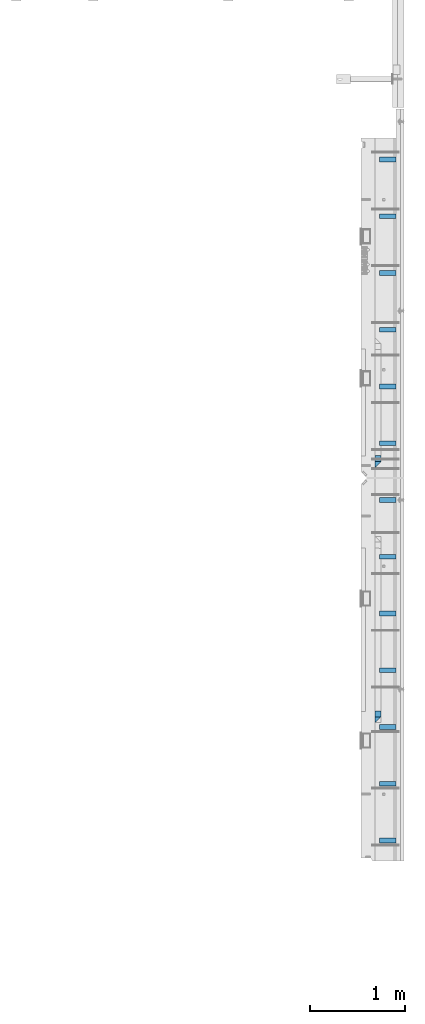
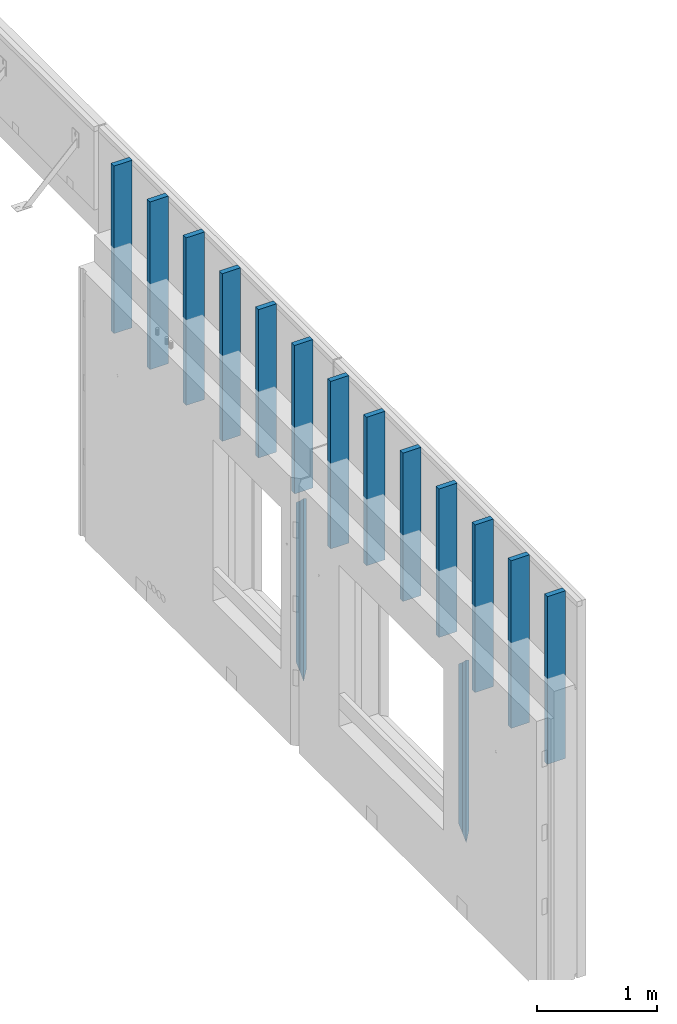
# One storey, part 5 of 153: 17 columns, 2 elements without a shape of their own.
"""IFC2X3 building model written with IfcOpenShell, lengths in millimetres."""

from ifc_helpers import new_model, si_unit, frame, origin_with_axes, place, context, subcontext, project, spatial, faceted_brep, material, type_object, element, aggregate, save


model = new_model("IFC2X3")

# Units and contexts
model_context = context("Model", 3, precision=1e-05, world=origin_with_axes())
body_context = subcontext(model_context, "Body", "Model", "MODEL_VIEW")
ifc_project = project(units=[si_unit("LENGTHUNIT", "METRE", prefix="MILLI"), si_unit("AREAUNIT", "SQUARE_METRE"), si_unit("VOLUMEUNIT", "CUBIC_METRE"), si_unit("MASSUNIT", "GRAM", prefix="KILO"), si_unit("TIMEUNIT", "SECOND"), si_unit("PLANEANGLEUNIT", "RADIAN"), si_unit("SOLIDANGLEUNIT", "STERADIAN"), si_unit("THERMODYNAMICTEMPERATUREUNIT", "DEGREE_CELSIUS"), si_unit("LUMINOUSINTENSITYUNIT", "LUMEN")], contexts=[model_context])

# Site, building, storey
site_placement = place(None, origin_with_axes())
site = spatial("IfcSite", under=ifc_project, at=site_placement, CompositionType="ELEMENT")
building_placement = place(site_placement, origin_with_axes())
building = spatial("IfcBuilding", under=site, at=building_placement, CompositionType="ELEMENT")
storey_placement = place(building_placement, origin_with_axes())
storey = spatial("IfcBuildingStorey", under=building, at=storey_placement, Name="8", CompositionType="ELEMENT", Elevation=0.0)

# Assembly, columns
assembly_1_placement = place(storey_placement, origin_with_axes())
assembly_1 = element("IfcElementAssembly", 1, at=assembly_1_placement, inside=storey, AssemblyPlace="NOTDEFINED", PredefinedType="REINFORCEMENT_UNIT")
ifc_material_1 = material(Name="TIMBER/T24")
column_type_1 = type_object("IfcColumnType", Name="PK50X175", PredefinedType="NOTDEFINED")
column_1_placement = place(assembly_1_placement, frame((35192.5, 13150.0002441406, 101870.0), z_axis=(-1.0, 3.00000001838171e-08, 0.0), x_axis=(0.0, 0.0, 1.0)))
column_1 = element("IfcColumn", 2, at=column_1_placement, type_object=column_type_1, material=ifc_material_1, ObjectType="PK50X175", context=body_context, shape_type="Brep", body=[
    faceted_brep([(0.0, 25.0, 87.5), (0.0, -25.0, 87.5), (1700.0, -25.0, 87.5), (1700.0, 25.0, 87.5), (0.0, -25.0, -87.5), (1700.0, -25.0, -87.5), (0.0, 25.0, -87.5), (1700.0, 25.0, -87.5)], [[[0, 1, 2, 3]], [[1, 4, 5, 2]], [[4, 6, 7, 5]], [[6, 0, 3, 7]], [[5, 7, 3, 2]], [[6, 4, 1, 0]]]),
])
column_2_placement = place(assembly_1_placement, frame((35192.5, 13750.0002441406, 101870.0), z_axis=(-1.0, 3.00000001838171e-08, 0.0), x_axis=(0.0, 0.0, 1.0)))
column_2 = element("IfcColumn", 3, at=column_2_placement, type_object=column_type_1, material=ifc_material_1, ObjectType="PK50X175", context=body_context, shape_type="Brep", body=[
    faceted_brep([(0.0, 25.0, 87.5), (0.0, -25.0, 87.5), (1700.0, -25.0, 87.5), (1700.0, 25.0, 87.5), (0.0, -25.0, -87.5), (1700.0, -25.0, -87.5), (0.0, 25.0, -87.5), (1700.0, 25.0, -87.5)], [[[0, 1, 2, 3]], [[1, 4, 5, 2]], [[4, 6, 7, 5]], [[6, 0, 3, 7]], [[5, 7, 3, 2]], [[6, 4, 1, 0]]]),
])
column_3_placement = place(assembly_1_placement, frame((35192.5, 14350.0002441406, 101870.0), z_axis=(-1.0, 3.00000001838171e-08, 0.0), x_axis=(0.0, 0.0, 1.0)))
column_3 = element("IfcColumn", 4, at=column_3_placement, type_object=column_type_1, material=ifc_material_1, ObjectType="PK50X175", context=body_context, shape_type="Brep", body=[
    faceted_brep([(0.0, 25.0, 87.5), (0.0, -25.0, 87.5), (1700.0, -25.0, 87.5), (1700.0, 25.0, 87.5), (0.0, -25.0, -87.5), (1700.0, -25.0, -87.5), (0.0, 25.0, -87.5), (1700.0, 25.0, -87.5)], [[[0, 1, 2, 3]], [[1, 4, 5, 2]], [[4, 6, 7, 5]], [[6, 0, 3, 7]], [[5, 7, 3, 2]], [[6, 4, 1, 0]]]),
])
column_4_placement = place(assembly_1_placement, frame((35192.5, 14950.0002441406, 102065.0), z_axis=(-1.0, 3.00000001838171e-08, 0.0), x_axis=(0.0, 0.0, 1.0)))
column_4 = element("IfcColumn", 5, at=column_4_placement, type_object=column_type_1, material=ifc_material_1, ObjectType="PK50X175", context=body_context, shape_type="Brep", body=[
    faceted_brep([(0.0, 25.0, 87.5), (0.0, -25.0, 87.5), (1505.0, -25.0, 87.5), (1505.0, 25.0, 87.5), (0.0, -25.0, -87.5), (1505.0, -25.0, -87.5), (0.0, 25.0, -87.5), (1505.0, 25.0, -87.5)], [[[0, 1, 2, 3]], [[1, 4, 5, 2]], [[4, 6, 7, 5]], [[6, 0, 3, 7]], [[5, 7, 3, 2]], [[6, 4, 1, 0]]]),
])
column_5_placement = place(assembly_1_placement, frame((35192.5, 15550.0002441406, 102065.0), z_axis=(-1.0, 3.00000001838171e-08, 0.0), x_axis=(0.0, 0.0, 1.0)))
column_5 = element("IfcColumn", 6, at=column_5_placement, type_object=column_type_1, material=ifc_material_1, ObjectType="PK50X175", context=body_context, shape_type="Brep", body=[
    faceted_brep([(0.0, 25.0, 87.5), (0.0, -25.0, 87.5), (1505.0, -25.0, 87.5), (1505.0, 25.0, 87.5), (0.0, -25.0, -87.5), (1505.0, -25.0, -87.5), (0.0, 25.0, -87.5), (1505.0, 25.0, -87.5)], [[[0, 1, 2, 3]], [[1, 4, 5, 2]], [[4, 6, 7, 5]], [[6, 0, 3, 7]], [[5, 7, 3, 2]], [[6, 4, 1, 0]]]),
])
column_6_placement = place(assembly_1_placement, frame((35192.5, 16150.0002441406, 102065.0), z_axis=(-1.0, 3.00000001838171e-08, 0.0), x_axis=(0.0, 0.0, 1.0)))
column_6 = element("IfcColumn", 7, at=column_6_placement, type_object=column_type_1, material=ifc_material_1, ObjectType="PK50X175", context=body_context, shape_type="Brep", body=[
    faceted_brep([(0.0, 25.0, 87.5), (0.0, -25.0, 87.5), (1505.0, -25.0, 87.5), (1505.0, 25.0, 87.5), (0.0, -25.0, -87.5), (1505.0, -25.0, -87.5), (0.0, 25.0, -87.5), (1505.0, 25.0, -87.5)], [[[0, 1, 2, 3]], [[1, 4, 5, 2]], [[4, 6, 7, 5]], [[6, 0, 3, 7]], [[5, 7, 3, 2]], [[6, 4, 1, 0]]]),
])
column_7_placement = place(assembly_1_placement, frame((35192.5, 16750.0002441406, 101870.0), z_axis=(-1.0, 3.00000001838171e-08, 0.0), x_axis=(0.0, 0.0, 1.0)))
column_7 = element("IfcColumn", 8, at=column_7_placement, type_object=column_type_1, material=ifc_material_1, ObjectType="PK50X175", context=body_context, shape_type="Brep", body=[
    faceted_brep([(0.0, 25.0, 87.5), (0.0, -25.0, 87.5), (1700.0, -25.0, 87.5), (1700.0, 25.0, 87.5), (0.0, -25.0, -87.5), (1700.0, -25.0, -87.5), (0.0, 25.0, -87.5), (1700.0, 25.0, -87.5)], [[[0, 1, 2, 3]], [[1, 4, 5, 2]], [[4, 6, 7, 5]], [[6, 0, 3, 7]], [[5, 7, 3, 2]], [[6, 4, 1, 0]]]),
])

assembly_2_placement = place(storey_placement, origin_with_axes())
assembly_2 = element("IfcElementAssembly", 9, at=assembly_2_placement, inside=storey, AssemblyPlace="NOTDEFINED", PredefinedType="REINFORCEMENT_UNIT")
column_8_placement = place(assembly_2_placement, frame((35192.5, 17350.0002441406, 102065.0), z_axis=(-1.0, 3.00000001838171e-08, 0.0), x_axis=(0.0, 0.0, 1.0)))
column_8 = element("IfcColumn", 10, at=column_8_placement, type_object=column_type_1, material=ifc_material_1, ObjectType="PK50X175", context=body_context, shape_type="Brep", body=[
    faceted_brep([(0.0, 25.0, 87.5), (0.0, -25.0, 87.5), (1505.0, -25.0, 87.5), (1505.0, 25.0, 87.5), (0.0, -25.0, -87.5), (1505.0, -25.0, -87.5), (0.0, 25.0, -87.5), (1505.0, 25.0, -87.5)], [[[0, 1, 2, 3]], [[1, 4, 5, 2]], [[4, 6, 7, 5]], [[6, 0, 3, 7]], [[5, 7, 3, 2]], [[6, 4, 1, 0]]]),
])
column_9_placement = place(assembly_2_placement, frame((35192.5, 17950.0002441406, 102065.0), z_axis=(-1.0, 3.00000001838171e-08, 0.0), x_axis=(0.0, 0.0, 1.0)))
column_9 = element("IfcColumn", 11, at=column_9_placement, type_object=column_type_1, material=ifc_material_1, ObjectType="PK50X175", context=body_context, shape_type="Brep", body=[
    faceted_brep([(0.0, 25.0, 87.5), (0.0, -25.0, 87.5), (1505.0, -25.0, 87.5), (1505.0, 25.0, 87.5), (0.0, -25.0, -87.5), (1505.0, -25.0, -87.5), (0.0, 25.0, -87.5), (1505.0, 25.0, -87.5)], [[[0, 1, 2, 3]], [[1, 4, 5, 2]], [[4, 6, 7, 5]], [[6, 0, 3, 7]], [[5, 7, 3, 2]], [[6, 4, 1, 0]]]),
])
column_10_placement = place(assembly_2_placement, frame((35192.5, 18550.0002441406, 101870.0), z_axis=(-1.0, 3.00000001838171e-08, 0.0), x_axis=(0.0, 0.0, 1.0)))
column_10 = element("IfcColumn", 12, at=column_10_placement, type_object=column_type_1, material=ifc_material_1, ObjectType="PK50X175", context=body_context, shape_type="Brep", body=[
    faceted_brep([(0.0, 25.0, 87.5), (0.0, -25.0, 87.5), (1700.0, -25.0, 87.5), (1700.0, 25.0, 87.5), (0.0, -25.0, -87.5), (1700.0, -25.0, -87.5), (0.0, 25.0, -87.5), (1700.0, 25.0, -87.5)], [[[0, 1, 2, 3]], [[1, 4, 5, 2]], [[4, 6, 7, 5]], [[6, 0, 3, 7]], [[5, 7, 3, 2]], [[6, 4, 1, 0]]]),
])
column_11_placement = place(assembly_2_placement, frame((35192.5, 19150.0002441406, 101870.0), z_axis=(-1.0, 3.00000001838171e-08, 0.0), x_axis=(0.0, 0.0, 1.0)))
column_11 = element("IfcColumn", 13, at=column_11_placement, type_object=column_type_1, material=ifc_material_1, ObjectType="PK50X175", context=body_context, shape_type="Brep", body=[
    faceted_brep([(0.0, 25.0, 87.5), (0.0, -25.0, 87.5), (1700.0, -25.0, 87.5), (1700.0, 25.0, 87.5), (0.0, -25.0, -87.5), (1700.0, -25.0, -87.5), (0.0, 25.0, -87.5), (1700.0, 25.0, -87.5)], [[[0, 1, 2, 3]], [[1, 4, 5, 2]], [[4, 6, 7, 5]], [[6, 0, 3, 7]], [[5, 7, 3, 2]], [[6, 4, 1, 0]]]),
])
column_12_placement = place(assembly_2_placement, frame((35192.5, 19750.0002441406, 101870.0), z_axis=(-1.0, 3.00000001838171e-08, 0.0), x_axis=(0.0, 0.0, 1.0)))
column_12 = element("IfcColumn", 14, at=column_12_placement, type_object=column_type_1, material=ifc_material_1, ObjectType="PK50X175", context=body_context, shape_type="Brep", body=[
    faceted_brep([(0.0, 25.0, 87.5), (0.0, -25.0, 87.5), (1700.0, -25.0, 87.5), (1700.0, 25.0, 87.5), (0.0, -25.0, -87.5), (1700.0, -25.0, -87.5), (0.0, 25.0, -87.5), (1700.0, 25.0, -87.5)], [[[0, 1, 2, 3]], [[1, 4, 5, 2]], [[4, 6, 7, 5]], [[6, 0, 3, 7]], [[5, 7, 3, 2]], [[6, 4, 1, 0]]]),
])
column_13_placement = place(assembly_2_placement, frame((35192.5, 20350.0002441406, 101870.0), z_axis=(-1.0, 3.00000001838171e-08, 0.0), x_axis=(0.0, 0.0, 1.0)))
column_13 = element("IfcColumn", 15, at=column_13_placement, type_object=column_type_1, material=ifc_material_1, ObjectType="PK50X175", context=body_context, shape_type="Brep", body=[
    faceted_brep([(0.0, 25.0, 87.5), (0.0, -25.0, 87.5), (1700.0, -25.0, 87.5), (1700.0, 25.0, 87.5), (0.0, -25.0, -87.5), (1700.0, -25.0, -87.5), (0.0, 25.0, -87.5), (1700.0, 25.0, -87.5)], [[[0, 1, 2, 3]], [[1, 4, 5, 2]], [[4, 6, 7, 5]], [[6, 0, 3, 7]], [[5, 7, 3, 2]], [[6, 4, 1, 0]]]),
])
ifc_material_2 = material(Name="CONCRETE/C25/30")
column_type_2 = type_object("IfcColumnType", PredefinedType="NOTDEFINED")
column_14_placement = place(assembly_2_placement, frame((35090.0, 17125.0018965848, 100320.0), z_axis=(0.0, 1.0, 0.0), x_axis=(0.0, 0.0, 1.0)))
column_14 = element("IfcColumn", 16, at=column_14_placement, type_object=column_type_2, material=ifc_material_2, Name="SK", context=body_context, shape_type="Brep", body=[
    faceted_brep([(1795.00000000001, -30.0, 30.0), (1855.0, -30.0, -30.0), (1795.00000000001, 30.0, 30.0), (60.0000000000073, 30.0, 30.0), (60.0000000000073, -30.0, 30.0), (0.0, -30.0, -30.0)], [[[0, 1, 2]], [[0, 2, 3, 4]], [[1, 0, 4, 5]], [[2, 1, 5, 3]], [[3, 5, 4]]]),
])

# Column
column_15_placement = place(assembly_1_placement, frame((35090.0, 14424.9995850056, 100320.0), z_axis=(0.0, 1.0, 0.0), x_axis=(0.0, 0.0, 1.0)))
column_15 = element("IfcColumn", 17, at=column_15_placement, type_object=column_type_2, material=ifc_material_2, Name="SK", context=body_context, shape_type="Brep", body=[
    faceted_brep([(1795.00000000001, -30.0, 30.0), (1855.0, -30.0, -30.0), (1795.00000000001, 30.0, 30.0), (60.0000000000073, 30.0, 30.0), (60.0000000000073, -30.0, 30.0), (0.0, -30.0, -30.0)], [[[0, 1, 2]], [[0, 2, 3, 4]], [[1, 0, 4, 5]], [[2, 1, 5, 3]], [[3, 5, 4]]]),
])

column_type_3 = type_object("IfcColumnType", PredefinedType="NOTDEFINED")
column_16_placement = place(assembly_2_placement, frame((35090.0, 17190.0018965848, 100380.0), z_axis=(0.0, 1.0, 0.0), x_axis=(0.0, 0.0, 1.0)))
column_16 = element("IfcColumn", 18, at=column_16_placement, type_object=column_type_3, material=ifc_material_2, Name="SK", context=body_context, shape_type="Brep", body=[
    faceted_brep([(1678.70787161513, 29.999999998452, 30.6741497967687), (1680.09783300469, -29.999999998452, 29.0525281752307), (1735.0, -30.0, -35.0), (1735.0, 30.0, -35.0), (56.29212838487, 29.999999998452, 30.6741497967687), (54.9021669952926, -29.999999998452, 29.0525281752307), (0.0, -30.0, -35.0), (0.0, 30.0, -35.0)], [[[0, 1, 2, 3]], [[1, 0, 4, 5]], [[2, 1, 5, 6]], [[3, 2, 6, 7]], [[0, 3, 7, 4]], [[4, 7, 6, 5]]]),
])

aggregate(assembly_2, [column_8, column_9, column_10, column_11, column_12, column_13, column_14, column_16])

column_17_placement = place(assembly_1_placement, frame((35090.0, 14489.9995850056, 100380.0), z_axis=(0.0, 1.0, 0.0), x_axis=(0.0, 0.0, 1.0)))
column_17 = element("IfcColumn", 19, at=column_17_placement, type_object=column_type_3, material=ifc_material_2, Name="SK", context=body_context, shape_type="Brep", body=[
    faceted_brep([(1680.09587116045, -30.0, 29.0548169935064), (1735.0, -30.0, -35.0), (1735.0, 30.0, -35.0), (1678.70590977081, 30.0, 30.6764386151262), (56.2940902291884, 30.0, 30.6764386151262), (54.9041288395238, -30.0, 29.0548169935064), (0.0, -30.0, -35.0), (0.0, 30.0, -35.0)], [[[0, 1, 2, 3]], [[0, 3, 4, 5]], [[1, 0, 5, 6]], [[2, 1, 6, 7]], [[3, 2, 7, 4]], [[5, 4, 7, 6]]]),
])

aggregate(assembly_1, [column_1, column_2, column_3, column_4, column_5, column_6, column_7, column_17, column_15])

save(model, "model.ifc")
